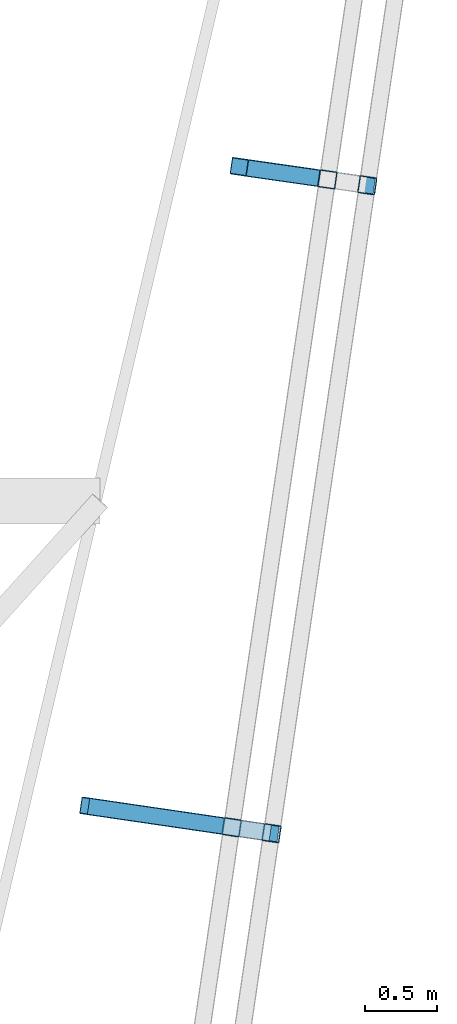
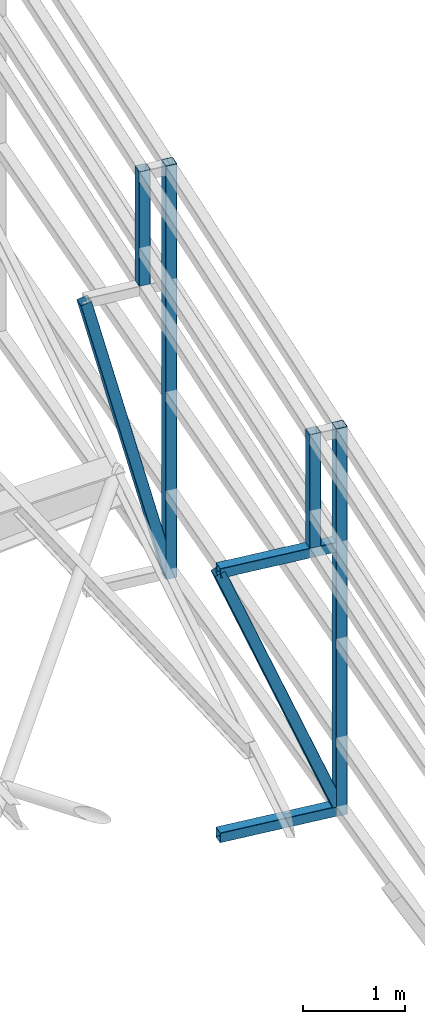
# One storey, part 122 of 215: 6 beams, 2 members, 8 elements without a shape of their own.
"""IFC2X3 building model written with IfcOpenShell, lengths in millimetres."""

from ifc_helpers import new_model, si_unit, frame, origin_with_axes, origin_2d_with_axis, place, context, subcontext, project, spatial, hollow_rectangle, extrude, material, type_object, element, aggregate, save


model = new_model("IFC2X3")

# Units and contexts
model_context = context("Model", 3, precision=1e-05, world=origin_with_axes())
body_context = subcontext(model_context, "Body", "Model", "MODEL_VIEW")
ifc_project = project(units=[si_unit("LENGTHUNIT", "METRE", prefix="MILLI"), si_unit("AREAUNIT", "SQUARE_METRE"), si_unit("VOLUMEUNIT", "CUBIC_METRE"), si_unit("MASSUNIT", "GRAM", prefix="KILO"), si_unit("TIMEUNIT", "SECOND"), si_unit("PLANEANGLEUNIT", "RADIAN"), si_unit("SOLIDANGLEUNIT", "STERADIAN"), si_unit("THERMODYNAMICTEMPERATUREUNIT", "DEGREE_CELSIUS"), si_unit("LUMINOUSINTENSITYUNIT", "LUMEN")], contexts=[model_context])

# Site, building, storey
site_placement = place(None, origin_with_axes())
site = spatial("IfcSite", under=ifc_project, at=site_placement, CompositionType="ELEMENT")
building_placement = place(site_placement, origin_with_axes())
building = spatial("IfcBuilding", under=site, at=building_placement, Name="Undefined", CompositionType="ELEMENT")
storey_placement = place(building_placement, origin_with_axes())
storey = spatial("IfcBuildingStorey", under=building, at=storey_placement, Name="Undefined", CompositionType="ELEMENT", Elevation=0.0)

# Assembly, beam
assembly_1_placement = place(storey_placement, origin_with_axes())
assembly_1 = element("IfcElementAssembly", 1, at=assembly_1_placement, inside=storey, Name="Steel Assembly", AssemblyPlace="NOTDEFINED", PredefinedType="RIGID_FRAME")
ifc_material = material(Name="STEEL/S275JR")
beam_type = type_object("IfcBeamType", PredefinedType="NOTDEFINED")
beam_1_placement = place(assembly_1_placement, frame((152553.93344565, 57909.4529377375, 5390.74705830537), z_axis=(0.989259672851491, -0.146168736978062, 0.0), x_axis=(9.50699999125844e-06, 6.43569999946843e-05, -0.999999997883897)))
beam_1 = element("IfcBeam", 2, at=beam_1_placement, type_object=beam_type, material=ifc_material, Name="LISSE", context=body_context, shape_type="SweptSolid", body=[
    extrude(hollow_rectangle(XDim=120.0, YDim=120.0, WallThickness=4.0, InnerFilletRadius=4.0, OuterFilletRadius=8.0, at=origin_2d_with_axis()), frame((1371.72416373084, 1.45519152283669e-11, 2.91038320784517e-11), z_axis=(-1.0, 0.0, 0.0), x_axis=(-6.93889390390723e-18, -1.0, -3.46944695195361e-18)), (0.0, 0.0, 1.0), 1371.7),
])
aggregate(assembly_1, [beam_1])

assembly_2_placement = place(storey_placement, origin_with_axes())
assembly_2 = element("IfcElementAssembly", 3, at=assembly_2_placement, inside=storey, Name="Steel Assembly", AssemblyPlace="NOTDEFINED", PredefinedType="RIGID_FRAME")
beam_2_placement = place(assembly_2_placement, frame((152830.728993123, 57868.5552112629, 5390.74705310479), z_axis=(0.989259672851491, -0.146168736978062, 0.0), x_axis=(0.0, 0.0, -1.0)))
beam_2 = element("IfcBeam", 4, at=beam_2_placement, type_object=beam_type, material=ifc_material, Name="LISSE", context=body_context, shape_type="SweptSolid", body=[
    extrude(hollow_rectangle(XDim=120.0, YDim=120.0, WallThickness=4.0, InnerFilletRadius=4.0, OuterFilletRadius=8.0, at=origin_2d_with_axis()), frame((4960.58985313255, 1.28228242291829e-22, -2.91038304557079e-11), z_axis=(-1.0, 0.0, 0.0), x_axis=(-6.93889390390723e-18, -1.0, -3.46944695195361e-18)), (0.0, 0.0, 1.0), 4960.6),
])
aggregate(assembly_2, [beam_2])

assembly_3_placement = place(storey_placement, origin_with_axes())
assembly_3 = element("IfcElementAssembly", 5, at=assembly_3_placement, inside=storey, Name="Steel Assembly", AssemblyPlace="NOTDEFINED", PredefinedType="RIGID_FRAME")
beam_3_placement = place(assembly_3_placement, frame((151889.210773393, 53410.677173971, 5199.71598346086), z_axis=(0.989259672851491, -0.146168736978062, 0.0), x_axis=(9.66599998929354e-06, 6.54179999871134e-05, -0.999999997813527)))
beam_3 = element("IfcBeam", 6, at=beam_3_placement, type_object=beam_type, material=ifc_material, Name="LISSE", context=body_context, shape_type="SweptSolid", body=[
    extrude(hollow_rectangle(XDim=120.0, YDim=120.0, WallThickness=4.0, InnerFilletRadius=4.0, OuterFilletRadius=8.0, at=origin_2d_with_axis()), frame((1360.99701320248, 1.84449489807551e-17, -6.40433981410343e-19), z_axis=(-1.0, 0.0, 0.0), x_axis=(-6.93889390390723e-18, -1.0, -3.46944695195361e-18)), (0.0, 0.0, 1.0), 1361.0),
])
aggregate(assembly_3, [beam_3])

assembly_4_placement = place(storey_placement, origin_with_axes())
assembly_4 = element("IfcElementAssembly", 7, at=assembly_4_placement, inside=storey, Name="Steel Assembly", AssemblyPlace="NOTDEFINED", PredefinedType="RIGID_FRAME")
beam_4_placement = place(assembly_4_placement, frame((152166.052828788, 53369.7735108059, 5199.71597814562), z_axis=(0.989259672851491, -0.146168736978062, 0.0), x_axis=(0.0, 0.0, -1.0)))
beam_4 = element("IfcBeam", 8, at=beam_4_placement, type_object=beam_type, material=ifc_material, Name="LISSE", context=body_context, shape_type="SweptSolid", body=[
    extrude(hollow_rectangle(XDim=120.0, YDim=120.0, WallThickness=4.0, InnerFilletRadius=4.0, OuterFilletRadius=8.0, at=origin_2d_with_axis()), frame((4649.94424791369, 0.0, 0.0), z_axis=(-1.0, 0.0, 0.0), x_axis=(-6.93889390390723e-18, -1.0, -3.46944695195361e-18)), (0.0, 0.0, 1.0), 4649.9),
])
aggregate(assembly_4, [beam_4])

assembly_5_placement = place(storey_placement, origin_with_axes())
assembly_5 = element("IfcElementAssembly", 9, at=assembly_5_placement, inside=storey, Name="Steel Assembly", AssemblyPlace="NOTDEFINED", PredefinedType="RIGID_FRAME")
beam_5_placement = place(assembly_5_placement, frame((150894.752768134, 53556.3571928248, 3778.71897303497), z_axis=(0.0, 0.0, -1.0), x_axis=(0.989474982254479, -0.144704041037214, 0.0)))
beam_5 = element("IfcBeam", 10, at=beam_5_placement, type_object=beam_type, material=ifc_material, Name="LISSE", context=body_context, shape_type="SweptSolid", body=[
    extrude(hollow_rectangle(XDim=120.0, YDim=120.0, WallThickness=4.0, InnerFilletRadius=4.0, OuterFilletRadius=8.0, at=origin_2d_with_axis()), frame((1275.07222084757, -1.45519152283669e-11, -9.09494701772928e-13), z_axis=(-1.0, 0.0, 0.0), x_axis=(-6.93889390390723e-18, -1.0, -3.46944695195361e-18)), (0.0, 0.0, 1.0), 1275.1),
])
aggregate(assembly_5, [beam_5])

assembly_6_placement = place(storey_placement, origin_with_axes())
assembly_6 = element("IfcElementAssembly", 11, at=assembly_6_placement, inside=storey, Name="Steel Assembly", AssemblyPlace="NOTDEFINED", PredefinedType="RIGID_FRAME")
beam_6_placement = place(assembly_6_placement, frame((150894.739627706, 53556.2682695792, 609.771735445375), z_axis=(0.0, 0.0, -1.0), x_axis=(0.989475191829099, -0.144702607975007, 0.0)))
beam_6 = element("IfcBeam", 12, at=beam_6_placement, type_object=beam_type, material=ifc_material, Name="LISSE", context=body_context, shape_type="SweptSolid", body=[
    extrude(hollow_rectangle(XDim=120.0, YDim=120.0, WallThickness=4.0, InnerFilletRadius=4.0, OuterFilletRadius=8.0, at=origin_2d_with_axis()), frame((1275.07230585201, 1.45873055941673e-11, 1.6875441456065e-20), z_axis=(-1.0, 0.0, 0.0), x_axis=(-6.93889390390723e-18, -1.0, -3.46944695195361e-18)), (0.0, 0.0, 1.0), 1275.1),
])
aggregate(assembly_6, [beam_6])

# Assembly, member
assembly_7_placement = place(storey_placement, origin_with_axes())
assembly_7 = element("IfcElementAssembly", 13, at=assembly_7_placement, inside=storey, Name="Steel Assembly", AssemblyPlace="NOTDEFINED", PredefinedType="RIGID_FRAME")
member_type = type_object("IfcMemberType", PredefinedType="NOTDEFINED")
member_1_placement = place(assembly_7_placement, frame((152821.200800594, 57871.1342747515, 490.157205007904), z_axis=(0.957869133323915, -0.144420580048836, 0.24825273308395), x_axis=(-0.245746532044622, 0.0352293740063963, 0.968693725175898)))
member_1 = element("IfcMember", 14, at=member_1_placement, type_object=member_type, material=ifc_material, Name="LISSE", context=body_context, shape_type="SweptSolid", body=[
    extrude(hollow_rectangle(XDim=120.0, YDim=120.0, WallThickness=4.0, InnerFilletRadius=4.0, OuterFilletRadius=8.0, at=origin_2d_with_axis()), frame((3580.97260538973, 4.27074810621208e-14, -2.91038304567337e-11), z_axis=(-1.0, 0.0, 0.0), x_axis=(-6.93889390390723e-18, -1.0, -3.46944695195361e-18)), (0.0, 0.0, 1.0), 3581.0),
])
aggregate(assembly_7, [member_1])

assembly_8_placement = place(storey_placement, origin_with_axes())
assembly_8 = element("IfcElementAssembly", 15, at=assembly_8_placement, inside=storey, Name="Steel Assembly", AssemblyPlace="NOTDEFINED", PredefinedType="RIGID_FRAME")
member_2_placement = place(assembly_8_placement, frame((152156.401904143, 53371.7698232044, 609.771735437869), z_axis=(0.91759118705335, -0.136706030007947, 0.373279888021698), x_axis=(-0.369348452878463, 0.0540408519822179, 0.927718333694727)))
member_2 = element("IfcMember", 16, at=member_2_placement, type_object=member_type, material=ifc_material, Name="LISSE", context=body_context, shape_type="SweptSolid", body=[
    extrude(hollow_rectangle(XDim=120.0, YDim=120.0, WallThickness=4.0, InnerFilletRadius=4.0, OuterFilletRadius=8.0, at=origin_2d_with_axis()), frame((3415.85061154959, 2.55539613121032e-14, 0.0), z_axis=(-1.0, 0.0, 0.0), x_axis=(-6.93889390390723e-18, -1.0, -3.46944695195361e-18)), (0.0, 0.0, 1.0), 3415.9),
])
aggregate(assembly_8, [member_2])

save(model, "model.ifc")
